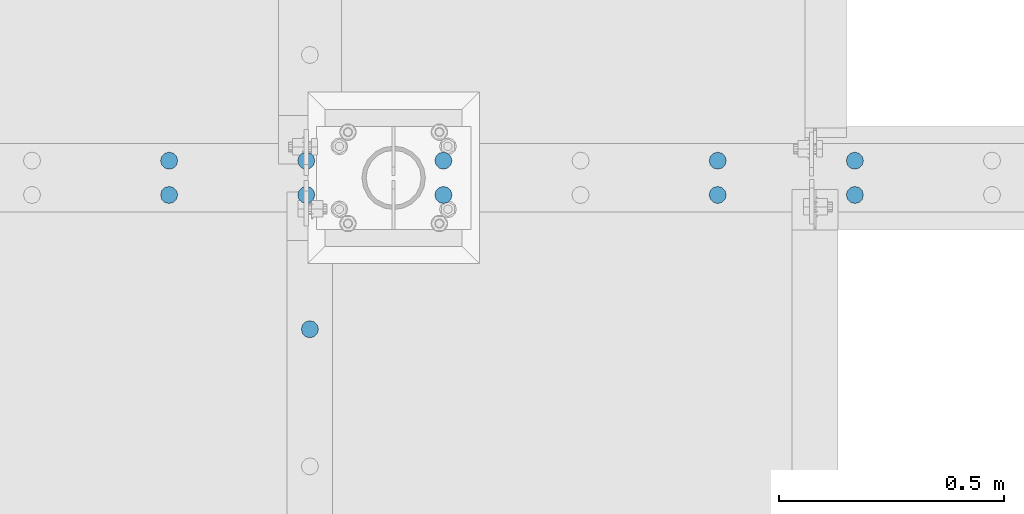
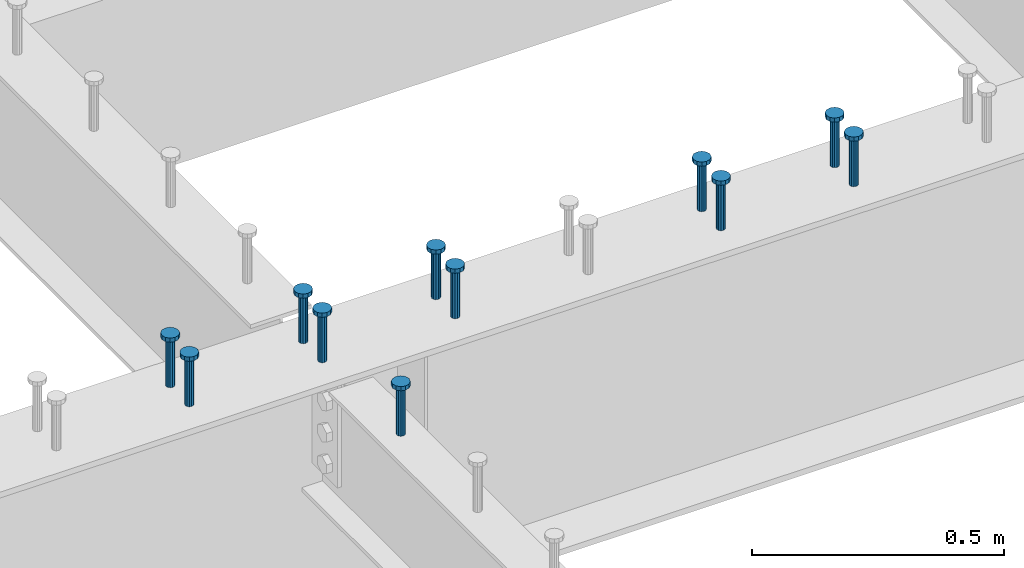
# One storey, part 148 of 975: 11 columns.
"""IFC2X3 building model written with IfcOpenShell, lengths in millimetres."""

from ifc_helpers import new_model, si_unit, frame, origin_with_axes, place, context, subcontext, project, spatial, faceted_brep, material, type_object, element, save


model = new_model("IFC2X3")

# Units and contexts
model_context = context("Model", 3, precision=1e-05, world=origin_with_axes())
body_context = subcontext(model_context, "Body", "Model", "MODEL_VIEW")
ifc_project = project(units=[si_unit("LENGTHUNIT", "METRE", prefix="MILLI"), si_unit("AREAUNIT", "SQUARE_METRE"), si_unit("VOLUMEUNIT", "CUBIC_METRE"), si_unit("MASSUNIT", "GRAM", prefix="KILO"), si_unit("TIMEUNIT", "SECOND"), si_unit("PLANEANGLEUNIT", "RADIAN"), si_unit("SOLIDANGLEUNIT", "STERADIAN"), si_unit("THERMODYNAMICTEMPERATUREUNIT", "DEGREE_CELSIUS"), si_unit("LUMINOUSINTENSITYUNIT", "LUMEN")], contexts=[model_context])

# Site, building, storey
site_placement = place(None, origin_with_axes())
site = spatial("IfcSite", under=ifc_project, at=site_placement, CompositionType="ELEMENT")
building_placement = place(site_placement, origin_with_axes())
building = spatial("IfcBuilding", under=site, at=building_placement, Name="Undefined", CompositionType="ELEMENT")
storey_placement = place(building_placement, origin_with_axes())
storey = spatial("IfcBuildingStorey", under=building, at=storey_placement, Name="Undefined", CompositionType="ELEMENT", Elevation=0.0)

# Columns
ifc_material = material(Name="STEEL/A108")
column_type = type_object("IfcColumnType", Name="STUD_3/4-DIA", PredefinedType="NOTDEFINED")
column_1_placement = place(storey_placement, frame((4290.48345841015, 5483.225, 3937.0), z_axis=(0.0, 1.0, 0.0), x_axis=(0.0, 0.0, 1.0)))
element("IfcColumn", 1, at=column_1_placement, inside=storey, type_object=column_type, material=ifc_material, ObjectType="STUD_3/4-DIA", context=body_context, shape_type="Brep", body=[
    faceted_brep([(0.0, -9.52000045776367, 0.0), (0.0, -8.25, -4.76000022888184), (115.57, -8.25, -4.76000022888184), (115.57, -9.52000045776367, 0.0), (0.0, -4.76000022888184, -8.25), (115.57, -4.76000022888184, -8.25), (0.0, 0.0, -9.52000045776367), (115.57, 0.0, -9.52000045776367), (0.0, 4.76000022888184, -8.25), (115.57, 4.76000022888184, -8.25), (0.0, 8.25, -4.76000022888184), (115.57, 8.25, -4.76000022888184), (0.0, 9.52000045776367, 0.0), (115.57, 9.52000045776367, 0.0), (0.0, 8.25, 4.76000022888184), (115.57, 8.25, 4.76000022888184), (0.0, 4.76000022888184, 8.25), (115.57, 4.76000022888184, 8.25), (0.0, 0.0, 9.52000045776367), (115.57, 0.0, 9.52000045776367), (0.0, -4.76000022888184, 8.25), (115.57, -4.76000022888184, 8.25), (0.0, -8.25, 4.76000022888184), (115.57, -8.25, 4.76000022888184), (116.84, -16.5, -9.52000045776367), (116.84, -19.0499992370605, 0.0), (116.84, -9.52000045776367, -16.5), (116.84, 0.0, -19.0499992370605), (116.84, 9.52000045776367, -16.5), (116.84, 16.5, -9.52000045776367), (116.84, 19.0499992370605, 0.0), (116.84, 16.5, 9.52000045776367), (116.84, 9.52000045776367, 16.5), (116.84, 0.0, 19.0499992370605), (116.84, -9.52000045776367, 16.5), (116.84, -16.5, 9.52000045776367), (127.0, -16.5, -9.52000045776367), (127.0, -19.0499992370605, 0.0), (127.0, -9.52000045776367, -16.5), (127.0, 0.0, -19.0499992370605), (127.0, 9.52000045776367, -16.5), (127.0, 16.5, -9.52000045776367), (127.0, 19.0499992370605, 0.0), (127.0, 16.5, 9.52000045776367), (127.0, 9.52000045776367, 16.5), (127.0, 0.0, 19.0499992370605), (127.0, -9.52000045776367, 16.5), (127.0, -16.5, 9.52000045776367)], [[[0, 1, 2, 3]], [[1, 4, 5, 2]], [[4, 6, 7, 5]], [[6, 8, 9, 7]], [[8, 10, 11, 9]], [[10, 12, 13, 11]], [[12, 14, 15, 13]], [[14, 16, 17, 15]], [[16, 18, 19, 17]], [[18, 20, 21, 19]], [[20, 22, 23, 21]], [[22, 0, 3, 23]], [[22, 20, 18, 16, 14, 12, 10, 8, 6, 4, 1, 0]], [[3, 2, 24, 25]], [[2, 5, 26, 24]], [[5, 7, 27, 26]], [[7, 9, 28, 27]], [[9, 11, 29, 28]], [[11, 13, 30, 29]], [[13, 15, 31, 30]], [[15, 17, 32, 31]], [[17, 19, 33, 32]], [[19, 21, 34, 33]], [[21, 23, 35, 34]], [[23, 3, 25, 35]], [[25, 24, 36, 37]], [[24, 26, 38, 36]], [[26, 27, 39, 38]], [[27, 28, 40, 39]], [[28, 29, 41, 40]], [[29, 30, 42, 41]], [[30, 31, 43, 42]], [[31, 32, 44, 43]], [[32, 33, 45, 44]], [[33, 34, 46, 45]], [[34, 35, 47, 46]], [[35, 25, 37, 47]], [[38, 39, 40, 41, 42, 43, 44, 45, 46, 47, 37, 36]]]),
])
column_2_placement = place(storey_placement, frame((5501.74595841015, 5781.675, 3937.0), z_axis=(0.0, 1.0, 0.0), x_axis=(0.0, 0.0, 1.0)))
element("IfcColumn", 2, at=column_2_placement, inside=storey, type_object=column_type, material=ifc_material, ObjectType="STUD_3/4-DIA", context=body_context, shape_type="Brep", body=[
    faceted_brep([(0.0, -9.52000045776367, 0.0), (0.0, -8.25, -4.76000022888184), (115.57, -8.25, -4.76000022888184), (115.57, -9.52000045776367, 0.0), (0.0, -4.76000022888184, -8.25), (115.57, -4.76000022888184, -8.25), (0.0, 0.0, -9.52000045776367), (115.57, 0.0, -9.52000045776367), (0.0, 4.76000022888184, -8.25), (115.57, 4.76000022888184, -8.25), (0.0, 8.25, -4.76000022888184), (115.57, 8.25, -4.76000022888184), (0.0, 9.52000045776367, 0.0), (115.57, 9.52000045776367, 0.0), (0.0, 8.25, 4.76000022888184), (115.57, 8.25, 4.76000022888184), (0.0, 4.76000022888184, 8.25), (115.57, 4.76000022888184, 8.25), (0.0, 0.0, 9.52000045776367), (115.57, 0.0, 9.52000045776367), (0.0, -4.76000022888184, 8.25), (115.57, -4.76000022888184, 8.25), (0.0, -8.25, 4.76000022888184), (115.57, -8.25, 4.76000022888184), (116.84, -16.5, -9.52000045776367), (116.84, -19.0499992370605, 0.0), (116.84, -9.52000045776367, -16.5), (116.84, 0.0, -19.0499992370605), (116.84, 9.52000045776367, -16.5), (116.84, 16.5, -9.52000045776367), (116.84, 19.0499992370605, 0.0), (116.84, 16.5, 9.52000045776367), (116.84, 9.52000045776367, 16.5), (116.84, 0.0, 19.0499992370605), (116.84, -9.52000045776367, 16.5), (116.84, -16.5, 9.52000045776367), (127.0, -16.5, -9.52000045776367), (127.0, -19.0499992370605, 0.0), (127.0, -9.52000045776367, -16.5), (127.0, 0.0, -19.0499992370605), (127.0, 9.52000045776367, -16.5), (127.0, 16.5, -9.52000045776367), (127.0, 19.0499992370605, 0.0), (127.0, 16.5, 9.52000045776367), (127.0, 9.52000045776367, 16.5), (127.0, 0.0, 19.0499992370605), (127.0, -9.52000045776367, 16.5), (127.0, -16.5, 9.52000045776367)], [[[0, 1, 2, 3]], [[1, 4, 5, 2]], [[4, 6, 7, 5]], [[6, 8, 9, 7]], [[8, 10, 11, 9]], [[10, 12, 13, 11]], [[12, 14, 15, 13]], [[14, 16, 17, 15]], [[16, 18, 19, 17]], [[18, 20, 21, 19]], [[20, 22, 23, 21]], [[22, 0, 3, 23]], [[22, 20, 18, 16, 14, 12, 10, 8, 6, 4, 1, 0]], [[3, 2, 24, 25]], [[2, 5, 26, 24]], [[5, 7, 27, 26]], [[7, 9, 28, 27]], [[9, 11, 29, 28]], [[11, 13, 30, 29]], [[13, 15, 31, 30]], [[15, 17, 32, 31]], [[17, 19, 33, 32]], [[19, 21, 34, 33]], [[21, 23, 35, 34]], [[23, 3, 25, 35]], [[25, 24, 36, 37]], [[24, 26, 38, 36]], [[26, 27, 39, 38]], [[27, 28, 40, 39]], [[28, 29, 41, 40]], [[29, 30, 42, 41]], [[30, 31, 43, 42]], [[31, 32, 44, 43]], [[32, 33, 45, 44]], [[33, 34, 46, 45]], [[34, 35, 47, 46]], [[35, 25, 37, 47]], [[38, 39, 40, 41, 42, 43, 44, 45, 46, 47, 37, 36]]]),
])
column_3_placement = place(storey_placement, frame((5501.74595841015, 5857.875, 3937.0), z_axis=(0.0, 1.0, 0.0), x_axis=(0.0, 0.0, 1.0)))
element("IfcColumn", 3, at=column_3_placement, inside=storey, type_object=column_type, material=ifc_material, ObjectType="STUD_3/4-DIA", context=body_context, shape_type="Brep", body=[
    faceted_brep([(0.0, -9.52000045776367, 0.0), (0.0, -8.25, -4.76000022888184), (115.57, -8.25, -4.76000022888184), (115.57, -9.52000045776367, 0.0), (0.0, -4.76000022888184, -8.25), (115.57, -4.76000022888184, -8.25), (0.0, 0.0, -9.52000045776367), (115.57, 0.0, -9.52000045776367), (0.0, 4.76000022888184, -8.25), (115.57, 4.76000022888184, -8.25), (0.0, 8.25, -4.76000022888184), (115.57, 8.25, -4.76000022888184), (0.0, 9.52000045776367, 0.0), (115.57, 9.52000045776367, 0.0), (0.0, 8.25, 4.76000022888184), (115.57, 8.25, 4.76000022888184), (0.0, 4.76000022888184, 8.25), (115.57, 4.76000022888184, 8.25), (0.0, 0.0, 9.52000045776367), (115.57, 0.0, 9.52000045776367), (0.0, -4.76000022888184, 8.25), (115.57, -4.76000022888184, 8.25), (0.0, -8.25, 4.76000022888184), (115.57, -8.25, 4.76000022888184), (116.84, -16.5, -9.52000045776367), (116.84, -19.0499992370605, 0.0), (116.84, -9.52000045776367, -16.5), (116.84, 0.0, -19.0499992370605), (116.84, 9.52000045776367, -16.5), (116.84, 16.5, -9.52000045776367), (116.84, 19.0499992370605, 0.0), (116.84, 16.5, 9.52000045776367), (116.84, 9.52000045776367, 16.5), (116.84, 0.0, 19.0499992370605), (116.84, -9.52000045776367, 16.5), (116.84, -16.5, 9.52000045776367), (127.0, -16.5, -9.52000045776367), (127.0, -19.0499992370605, 0.0), (127.0, -9.52000045776367, -16.5), (127.0, 0.0, -19.0499992370605), (127.0, 9.52000045776367, -16.5), (127.0, 16.5, -9.52000045776367), (127.0, 19.0499992370605, 0.0), (127.0, 16.5, 9.52000045776367), (127.0, 9.52000045776367, 16.5), (127.0, 0.0, 19.0499992370605), (127.0, -9.52000045776367, 16.5), (127.0, -16.5, 9.52000045776367)], [[[0, 1, 2, 3]], [[1, 4, 5, 2]], [[4, 6, 7, 5]], [[6, 8, 9, 7]], [[8, 10, 11, 9]], [[10, 12, 13, 11]], [[12, 14, 15, 13]], [[14, 16, 17, 15]], [[16, 18, 19, 17]], [[18, 20, 21, 19]], [[20, 22, 23, 21]], [[22, 0, 3, 23]], [[22, 20, 18, 16, 14, 12, 10, 8, 6, 4, 1, 0]], [[3, 2, 24, 25]], [[2, 5, 26, 24]], [[5, 7, 27, 26]], [[7, 9, 28, 27]], [[9, 11, 29, 28]], [[11, 13, 30, 29]], [[13, 15, 31, 30]], [[15, 17, 32, 31]], [[17, 19, 33, 32]], [[19, 21, 34, 33]], [[21, 23, 35, 34]], [[23, 3, 25, 35]], [[25, 24, 36, 37]], [[24, 26, 38, 36]], [[26, 27, 39, 38]], [[27, 28, 40, 39]], [[28, 29, 41, 40]], [[29, 30, 42, 41]], [[30, 31, 43, 42]], [[31, 32, 44, 43]], [[32, 33, 45, 44]], [[33, 34, 46, 45]], [[34, 35, 47, 46]], [[35, 25, 37, 47]], [[38, 39, 40, 41, 42, 43, 44, 45, 46, 47, 37, 36]]]),
])
column_4_placement = place(storey_placement, frame((5196.94595841015, 5781.675, 3937.0), z_axis=(0.0, 1.0, 0.0), x_axis=(0.0, 0.0, 1.0)))
element("IfcColumn", 4, at=column_4_placement, inside=storey, type_object=column_type, material=ifc_material, ObjectType="STUD_3/4-DIA", context=body_context, shape_type="Brep", body=[
    faceted_brep([(0.0, -9.52000045776367, 0.0), (0.0, -8.25, -4.76000022888184), (115.57, -8.25, -4.76000022888184), (115.57, -9.52000045776367, 0.0), (0.0, -4.76000022888184, -8.25), (115.57, -4.76000022888184, -8.25), (0.0, 0.0, -9.52000045776367), (115.57, 0.0, -9.52000045776367), (0.0, 4.76000022888184, -8.25), (115.57, 4.76000022888184, -8.25), (0.0, 8.25, -4.76000022888184), (115.57, 8.25, -4.76000022888184), (0.0, 9.52000045776367, 0.0), (115.57, 9.52000045776367, 0.0), (0.0, 8.25, 4.76000022888184), (115.57, 8.25, 4.76000022888184), (0.0, 4.76000022888184, 8.25), (115.57, 4.76000022888184, 8.25), (0.0, 0.0, 9.52000045776367), (115.57, 0.0, 9.52000045776367), (0.0, -4.76000022888184, 8.25), (115.57, -4.76000022888184, 8.25), (0.0, -8.25, 4.76000022888184), (115.57, -8.25, 4.76000022888184), (116.84, -16.5, -9.52000045776367), (116.84, -19.0499992370605, 0.0), (116.84, -9.52000045776367, -16.5), (116.84, 0.0, -19.0499992370605), (116.84, 9.52000045776367, -16.5), (116.84, 16.5, -9.52000045776367), (116.84, 19.0499992370605, 0.0), (116.84, 16.5, 9.52000045776367), (116.84, 9.52000045776367, 16.5), (116.84, 0.0, 19.0499992370605), (116.84, -9.52000045776367, 16.5), (116.84, -16.5, 9.52000045776367), (127.0, -16.5, -9.52000045776367), (127.0, -19.0499992370605, 0.0), (127.0, -9.52000045776367, -16.5), (127.0, 0.0, -19.0499992370605), (127.0, 9.52000045776367, -16.5), (127.0, 16.5, -9.52000045776367), (127.0, 19.0499992370605, 0.0), (127.0, 16.5, 9.52000045776367), (127.0, 9.52000045776367, 16.5), (127.0, 0.0, 19.0499992370605), (127.0, -9.52000045776367, 16.5), (127.0, -16.5, 9.52000045776367)], [[[0, 1, 2, 3]], [[1, 4, 5, 2]], [[4, 6, 7, 5]], [[6, 8, 9, 7]], [[8, 10, 11, 9]], [[10, 12, 13, 11]], [[12, 14, 15, 13]], [[14, 16, 17, 15]], [[16, 18, 19, 17]], [[18, 20, 21, 19]], [[20, 22, 23, 21]], [[22, 0, 3, 23]], [[22, 20, 18, 16, 14, 12, 10, 8, 6, 4, 1, 0]], [[3, 2, 24, 25]], [[2, 5, 26, 24]], [[5, 7, 27, 26]], [[7, 9, 28, 27]], [[9, 11, 29, 28]], [[11, 13, 30, 29]], [[13, 15, 31, 30]], [[15, 17, 32, 31]], [[17, 19, 33, 32]], [[19, 21, 34, 33]], [[21, 23, 35, 34]], [[23, 3, 25, 35]], [[25, 24, 36, 37]], [[24, 26, 38, 36]], [[26, 27, 39, 38]], [[27, 28, 40, 39]], [[28, 29, 41, 40]], [[29, 30, 42, 41]], [[30, 31, 43, 42]], [[31, 32, 44, 43]], [[32, 33, 45, 44]], [[33, 34, 46, 45]], [[34, 35, 47, 46]], [[35, 25, 37, 47]], [[38, 39, 40, 41, 42, 43, 44, 45, 46, 47, 37, 36]]]),
])
column_5_placement = place(storey_placement, frame((5196.94595841015, 5857.875, 3937.0), z_axis=(0.0, 1.0, 0.0), x_axis=(0.0, 0.0, 1.0)))
element("IfcColumn", 5, at=column_5_placement, inside=storey, type_object=column_type, material=ifc_material, ObjectType="STUD_3/4-DIA", context=body_context, shape_type="Brep", body=[
    faceted_brep([(0.0, -9.52000045776367, 0.0), (0.0, -8.25, -4.76000022888184), (115.57, -8.25, -4.76000022888184), (115.57, -9.52000045776367, 0.0), (0.0, -4.76000022888184, -8.25), (115.57, -4.76000022888184, -8.25), (0.0, 0.0, -9.52000045776367), (115.57, 0.0, -9.52000045776367), (0.0, 4.76000022888184, -8.25), (115.57, 4.76000022888184, -8.25), (0.0, 8.25, -4.76000022888184), (115.57, 8.25, -4.76000022888184), (0.0, 9.52000045776367, 0.0), (115.57, 9.52000045776367, 0.0), (0.0, 8.25, 4.76000022888184), (115.57, 8.25, 4.76000022888184), (0.0, 4.76000022888184, 8.25), (115.57, 4.76000022888184, 8.25), (0.0, 0.0, 9.52000045776367), (115.57, 0.0, 9.52000045776367), (0.0, -4.76000022888184, 8.25), (115.57, -4.76000022888184, 8.25), (0.0, -8.25, 4.76000022888184), (115.57, -8.25, 4.76000022888184), (116.84, -16.5, -9.52000045776367), (116.84, -19.0499992370605, 0.0), (116.84, -9.52000045776367, -16.5), (116.84, 0.0, -19.0499992370605), (116.84, 9.52000045776367, -16.5), (116.84, 16.5, -9.52000045776367), (116.84, 19.0499992370605, 0.0), (116.84, 16.5, 9.52000045776367), (116.84, 9.52000045776367, 16.5), (116.84, 0.0, 19.0499992370605), (116.84, -9.52000045776367, 16.5), (116.84, -16.5, 9.52000045776367), (127.0, -16.5, -9.52000045776367), (127.0, -19.0499992370605, 0.0), (127.0, -9.52000045776367, -16.5), (127.0, 0.0, -19.0499992370605), (127.0, 9.52000045776367, -16.5), (127.0, 16.5, -9.52000045776367), (127.0, 19.0499992370605, 0.0), (127.0, 16.5, 9.52000045776367), (127.0, 9.52000045776367, 16.5), (127.0, 0.0, 19.0499992370605), (127.0, -9.52000045776367, 16.5), (127.0, -16.5, 9.52000045776367)], [[[0, 1, 2, 3]], [[1, 4, 5, 2]], [[4, 6, 7, 5]], [[6, 8, 9, 7]], [[8, 10, 11, 9]], [[10, 12, 13, 11]], [[12, 14, 15, 13]], [[14, 16, 17, 15]], [[16, 18, 19, 17]], [[18, 20, 21, 19]], [[20, 22, 23, 21]], [[22, 0, 3, 23]], [[22, 20, 18, 16, 14, 12, 10, 8, 6, 4, 1, 0]], [[3, 2, 24, 25]], [[2, 5, 26, 24]], [[5, 7, 27, 26]], [[7, 9, 28, 27]], [[9, 11, 29, 28]], [[11, 13, 30, 29]], [[13, 15, 31, 30]], [[15, 17, 32, 31]], [[17, 19, 33, 32]], [[19, 21, 34, 33]], [[21, 23, 35, 34]], [[23, 3, 25, 35]], [[25, 24, 36, 37]], [[24, 26, 38, 36]], [[26, 27, 39, 38]], [[27, 28, 40, 39]], [[28, 29, 41, 40]], [[29, 30, 42, 41]], [[30, 31, 43, 42]], [[31, 32, 44, 43]], [[32, 33, 45, 44]], [[33, 34, 46, 45]], [[34, 35, 47, 46]], [[35, 25, 37, 47]], [[38, 39, 40, 41, 42, 43, 44, 45, 46, 47, 37, 36]]]),
])
column_6_placement = place(storey_placement, frame((4587.34595841015, 5781.675, 3937.0), z_axis=(0.0, 1.0, 0.0), x_axis=(0.0, 0.0, 1.0)))
element("IfcColumn", 6, at=column_6_placement, inside=storey, type_object=column_type, material=ifc_material, ObjectType="STUD_3/4-DIA", context=body_context, shape_type="Brep", body=[
    faceted_brep([(0.0, -9.52000045776367, 0.0), (0.0, -8.25, -4.76000022888184), (115.57, -8.25, -4.76000022888184), (115.57, -9.52000045776367, 0.0), (0.0, -4.76000022888184, -8.25), (115.57, -4.76000022888184, -8.25), (0.0, 0.0, -9.52000045776367), (115.57, 0.0, -9.52000045776367), (0.0, 4.76000022888184, -8.25), (115.57, 4.76000022888184, -8.25), (0.0, 8.25, -4.76000022888184), (115.57, 8.25, -4.76000022888184), (0.0, 9.52000045776367, 0.0), (115.57, 9.52000045776367, 0.0), (0.0, 8.25, 4.76000022888184), (115.57, 8.25, 4.76000022888184), (0.0, 4.76000022888184, 8.25), (115.57, 4.76000022888184, 8.25), (0.0, 0.0, 9.52000045776367), (115.57, 0.0, 9.52000045776367), (0.0, -4.76000022888184, 8.25), (115.57, -4.76000022888184, 8.25), (0.0, -8.25, 4.76000022888184), (115.57, -8.25, 4.76000022888184), (116.84, -16.5, -9.52000045776367), (116.84, -19.0499992370605, 0.0), (116.84, -9.52000045776367, -16.5), (116.84, 0.0, -19.0499992370605), (116.84, 9.52000045776367, -16.5), (116.84, 16.5, -9.52000045776367), (116.84, 19.0499992370605, 0.0), (116.84, 16.5, 9.52000045776367), (116.84, 9.52000045776367, 16.5), (116.84, 0.0, 19.0499992370605), (116.84, -9.52000045776367, 16.5), (116.84, -16.5, 9.52000045776367), (127.0, -16.5, -9.52000045776367), (127.0, -19.0499992370605, 0.0), (127.0, -9.52000045776367, -16.5), (127.0, 0.0, -19.0499992370605), (127.0, 9.52000045776367, -16.5), (127.0, 16.5, -9.52000045776367), (127.0, 19.0499992370605, 0.0), (127.0, 16.5, 9.52000045776367), (127.0, 9.52000045776367, 16.5), (127.0, 0.0, 19.0499992370605), (127.0, -9.52000045776367, 16.5), (127.0, -16.5, 9.52000045776367)], [[[0, 1, 2, 3]], [[1, 4, 5, 2]], [[4, 6, 7, 5]], [[6, 8, 9, 7]], [[8, 10, 11, 9]], [[10, 12, 13, 11]], [[12, 14, 15, 13]], [[14, 16, 17, 15]], [[16, 18, 19, 17]], [[18, 20, 21, 19]], [[20, 22, 23, 21]], [[22, 0, 3, 23]], [[22, 20, 18, 16, 14, 12, 10, 8, 6, 4, 1, 0]], [[3, 2, 24, 25]], [[2, 5, 26, 24]], [[5, 7, 27, 26]], [[7, 9, 28, 27]], [[9, 11, 29, 28]], [[11, 13, 30, 29]], [[13, 15, 31, 30]], [[15, 17, 32, 31]], [[17, 19, 33, 32]], [[19, 21, 34, 33]], [[21, 23, 35, 34]], [[23, 3, 25, 35]], [[25, 24, 36, 37]], [[24, 26, 38, 36]], [[26, 27, 39, 38]], [[27, 28, 40, 39]], [[28, 29, 41, 40]], [[29, 30, 42, 41]], [[30, 31, 43, 42]], [[31, 32, 44, 43]], [[32, 33, 45, 44]], [[33, 34, 46, 45]], [[34, 35, 47, 46]], [[35, 25, 37, 47]], [[38, 39, 40, 41, 42, 43, 44, 45, 46, 47, 37, 36]]]),
])
column_7_placement = place(storey_placement, frame((4587.34595841015, 5857.875, 3937.0), z_axis=(0.0, 1.0, 0.0), x_axis=(0.0, 0.0, 1.0)))
element("IfcColumn", 7, at=column_7_placement, inside=storey, type_object=column_type, material=ifc_material, ObjectType="STUD_3/4-DIA", context=body_context, shape_type="Brep", body=[
    faceted_brep([(0.0, -9.52000045776367, 0.0), (0.0, -8.25, -4.76000022888184), (115.57, -8.25, -4.76000022888184), (115.57, -9.52000045776367, 0.0), (0.0, -4.76000022888184, -8.25), (115.57, -4.76000022888184, -8.25), (0.0, 0.0, -9.52000045776367), (115.57, 0.0, -9.52000045776367), (0.0, 4.76000022888184, -8.25), (115.57, 4.76000022888184, -8.25), (0.0, 8.25, -4.76000022888184), (115.57, 8.25, -4.76000022888184), (0.0, 9.52000045776367, 0.0), (115.57, 9.52000045776367, 0.0), (0.0, 8.25, 4.76000022888184), (115.57, 8.25, 4.76000022888184), (0.0, 4.76000022888184, 8.25), (115.57, 4.76000022888184, 8.25), (0.0, 0.0, 9.52000045776367), (115.57, 0.0, 9.52000045776367), (0.0, -4.76000022888184, 8.25), (115.57, -4.76000022888184, 8.25), (0.0, -8.25, 4.76000022888184), (115.57, -8.25, 4.76000022888184), (116.84, -16.5, -9.52000045776367), (116.84, -19.0499992370605, 0.0), (116.84, -9.52000045776367, -16.5), (116.84, 0.0, -19.0499992370605), (116.84, 9.52000045776367, -16.5), (116.84, 16.5, -9.52000045776367), (116.84, 19.0499992370605, 0.0), (116.84, 16.5, 9.52000045776367), (116.84, 9.52000045776367, 16.5), (116.84, 0.0, 19.0499992370605), (116.84, -9.52000045776367, 16.5), (116.84, -16.5, 9.52000045776367), (127.0, -16.5, -9.52000045776367), (127.0, -19.0499992370605, 0.0), (127.0, -9.52000045776367, -16.5), (127.0, 0.0, -19.0499992370605), (127.0, 9.52000045776367, -16.5), (127.0, 16.5, -9.52000045776367), (127.0, 19.0499992370605, 0.0), (127.0, 16.5, 9.52000045776367), (127.0, 9.52000045776367, 16.5), (127.0, 0.0, 19.0499992370605), (127.0, -9.52000045776367, 16.5), (127.0, -16.5, 9.52000045776367)], [[[0, 1, 2, 3]], [[1, 4, 5, 2]], [[4, 6, 7, 5]], [[6, 8, 9, 7]], [[8, 10, 11, 9]], [[10, 12, 13, 11]], [[12, 14, 15, 13]], [[14, 16, 17, 15]], [[16, 18, 19, 17]], [[18, 20, 21, 19]], [[20, 22, 23, 21]], [[22, 0, 3, 23]], [[22, 20, 18, 16, 14, 12, 10, 8, 6, 4, 1, 0]], [[3, 2, 24, 25]], [[2, 5, 26, 24]], [[5, 7, 27, 26]], [[7, 9, 28, 27]], [[9, 11, 29, 28]], [[11, 13, 30, 29]], [[13, 15, 31, 30]], [[15, 17, 32, 31]], [[17, 19, 33, 32]], [[19, 21, 34, 33]], [[21, 23, 35, 34]], [[23, 3, 25, 35]], [[25, 24, 36, 37]], [[24, 26, 38, 36]], [[26, 27, 39, 38]], [[27, 28, 40, 39]], [[28, 29, 41, 40]], [[29, 30, 42, 41]], [[30, 31, 43, 42]], [[31, 32, 44, 43]], [[32, 33, 45, 44]], [[33, 34, 46, 45]], [[34, 35, 47, 46]], [[35, 25, 37, 47]], [[38, 39, 40, 41, 42, 43, 44, 45, 46, 47, 37, 36]]]),
])
column_8_placement = place(storey_placement, frame((4282.54595841015, 5781.675, 3937.0), z_axis=(0.0, 1.0, 0.0), x_axis=(0.0, 0.0, 1.0)))
element("IfcColumn", 8, at=column_8_placement, inside=storey, type_object=column_type, material=ifc_material, ObjectType="STUD_3/4-DIA", context=body_context, shape_type="Brep", body=[
    faceted_brep([(0.0, -9.52000045776367, 0.0), (0.0, -8.25, -4.76000022888184), (115.57, -8.25, -4.76000022888184), (115.57, -9.52000045776367, 0.0), (0.0, -4.76000022888184, -8.25), (115.57, -4.76000022888184, -8.25), (0.0, 0.0, -9.52000045776367), (115.57, 0.0, -9.52000045776367), (0.0, 4.76000022888184, -8.25), (115.57, 4.76000022888184, -8.25), (0.0, 8.25, -4.76000022888184), (115.57, 8.25, -4.76000022888184), (0.0, 9.52000045776367, 0.0), (115.57, 9.52000045776367, 0.0), (0.0, 8.25, 4.76000022888184), (115.57, 8.25, 4.76000022888184), (0.0, 4.76000022888184, 8.25), (115.57, 4.76000022888184, 8.25), (0.0, 0.0, 9.52000045776367), (115.57, 0.0, 9.52000045776367), (0.0, -4.76000022888184, 8.25), (115.57, -4.76000022888184, 8.25), (0.0, -8.25, 4.76000022888184), (115.57, -8.25, 4.76000022888184), (116.84, -16.5, -9.52000045776367), (116.84, -19.0499992370605, 0.0), (116.84, -9.52000045776367, -16.5), (116.84, 0.0, -19.0499992370605), (116.84, 9.52000045776367, -16.5), (116.84, 16.5, -9.52000045776367), (116.84, 19.0499992370605, 0.0), (116.84, 16.5, 9.52000045776367), (116.84, 9.52000045776367, 16.5), (116.84, 0.0, 19.0499992370605), (116.84, -9.52000045776367, 16.5), (116.84, -16.5, 9.52000045776367), (127.0, -16.5, -9.52000045776367), (127.0, -19.0499992370605, 0.0), (127.0, -9.52000045776367, -16.5), (127.0, 0.0, -19.0499992370605), (127.0, 9.52000045776367, -16.5), (127.0, 16.5, -9.52000045776367), (127.0, 19.0499992370605, 0.0), (127.0, 16.5, 9.52000045776367), (127.0, 9.52000045776367, 16.5), (127.0, 0.0, 19.0499992370605), (127.0, -9.52000045776367, 16.5), (127.0, -16.5, 9.52000045776367)], [[[0, 1, 2, 3]], [[1, 4, 5, 2]], [[4, 6, 7, 5]], [[6, 8, 9, 7]], [[8, 10, 11, 9]], [[10, 12, 13, 11]], [[12, 14, 15, 13]], [[14, 16, 17, 15]], [[16, 18, 19, 17]], [[18, 20, 21, 19]], [[20, 22, 23, 21]], [[22, 0, 3, 23]], [[22, 20, 18, 16, 14, 12, 10, 8, 6, 4, 1, 0]], [[3, 2, 24, 25]], [[2, 5, 26, 24]], [[5, 7, 27, 26]], [[7, 9, 28, 27]], [[9, 11, 29, 28]], [[11, 13, 30, 29]], [[13, 15, 31, 30]], [[15, 17, 32, 31]], [[17, 19, 33, 32]], [[19, 21, 34, 33]], [[21, 23, 35, 34]], [[23, 3, 25, 35]], [[25, 24, 36, 37]], [[24, 26, 38, 36]], [[26, 27, 39, 38]], [[27, 28, 40, 39]], [[28, 29, 41, 40]], [[29, 30, 42, 41]], [[30, 31, 43, 42]], [[31, 32, 44, 43]], [[32, 33, 45, 44]], [[33, 34, 46, 45]], [[34, 35, 47, 46]], [[35, 25, 37, 47]], [[38, 39, 40, 41, 42, 43, 44, 45, 46, 47, 37, 36]]]),
])
column_9_placement = place(storey_placement, frame((4282.54595841015, 5857.875, 3937.0), z_axis=(0.0, 1.0, 0.0), x_axis=(0.0, 0.0, 1.0)))
element("IfcColumn", 9, at=column_9_placement, inside=storey, type_object=column_type, material=ifc_material, ObjectType="STUD_3/4-DIA", context=body_context, shape_type="Brep", body=[
    faceted_brep([(0.0, -9.52000045776367, 0.0), (0.0, -8.25, -4.76000022888184), (115.57, -8.25, -4.76000022888184), (115.57, -9.52000045776367, 0.0), (0.0, -4.76000022888184, -8.25), (115.57, -4.76000022888184, -8.25), (0.0, 0.0, -9.52000045776367), (115.57, 0.0, -9.52000045776367), (0.0, 4.76000022888184, -8.25), (115.57, 4.76000022888184, -8.25), (0.0, 8.25, -4.76000022888184), (115.57, 8.25, -4.76000022888184), (0.0, 9.52000045776367, 0.0), (115.57, 9.52000045776367, 0.0), (0.0, 8.25, 4.76000022888184), (115.57, 8.25, 4.76000022888184), (0.0, 4.76000022888184, 8.25), (115.57, 4.76000022888184, 8.25), (0.0, 0.0, 9.52000045776367), (115.57, 0.0, 9.52000045776367), (0.0, -4.76000022888184, 8.25), (115.57, -4.76000022888184, 8.25), (0.0, -8.25, 4.76000022888184), (115.57, -8.25, 4.76000022888184), (116.84, -16.5, -9.52000045776367), (116.84, -19.0499992370605, 0.0), (116.84, -9.52000045776367, -16.5), (116.84, 0.0, -19.0499992370605), (116.84, 9.52000045776367, -16.5), (116.84, 16.5, -9.52000045776367), (116.84, 19.0499992370605, 0.0), (116.84, 16.5, 9.52000045776367), (116.84, 9.52000045776367, 16.5), (116.84, 0.0, 19.0499992370605), (116.84, -9.52000045776367, 16.5), (116.84, -16.5, 9.52000045776367), (127.0, -16.5, -9.52000045776367), (127.0, -19.0499992370605, 0.0), (127.0, -9.52000045776367, -16.5), (127.0, 0.0, -19.0499992370605), (127.0, 9.52000045776367, -16.5), (127.0, 16.5, -9.52000045776367), (127.0, 19.0499992370605, 0.0), (127.0, 16.5, 9.52000045776367), (127.0, 9.52000045776367, 16.5), (127.0, 0.0, 19.0499992370605), (127.0, -9.52000045776367, 16.5), (127.0, -16.5, 9.52000045776367)], [[[0, 1, 2, 3]], [[1, 4, 5, 2]], [[4, 6, 7, 5]], [[6, 8, 9, 7]], [[8, 10, 11, 9]], [[10, 12, 13, 11]], [[12, 14, 15, 13]], [[14, 16, 17, 15]], [[16, 18, 19, 17]], [[18, 20, 21, 19]], [[20, 22, 23, 21]], [[22, 0, 3, 23]], [[22, 20, 18, 16, 14, 12, 10, 8, 6, 4, 1, 0]], [[3, 2, 24, 25]], [[2, 5, 26, 24]], [[5, 7, 27, 26]], [[7, 9, 28, 27]], [[9, 11, 29, 28]], [[11, 13, 30, 29]], [[13, 15, 31, 30]], [[15, 17, 32, 31]], [[17, 19, 33, 32]], [[19, 21, 34, 33]], [[21, 23, 35, 34]], [[23, 3, 25, 35]], [[25, 24, 36, 37]], [[24, 26, 38, 36]], [[26, 27, 39, 38]], [[27, 28, 40, 39]], [[28, 29, 41, 40]], [[29, 30, 42, 41]], [[30, 31, 43, 42]], [[31, 32, 44, 43]], [[32, 33, 45, 44]], [[33, 34, 46, 45]], [[34, 35, 47, 46]], [[35, 25, 37, 47]], [[38, 39, 40, 41, 42, 43, 44, 45, 46, 47, 37, 36]]]),
])
column_10_placement = place(storey_placement, frame((3977.74595841015, 5781.675, 3937.0), z_axis=(0.0, 1.0, 0.0), x_axis=(0.0, 0.0, 1.0)))
element("IfcColumn", 10, at=column_10_placement, inside=storey, type_object=column_type, material=ifc_material, ObjectType="STUD_3/4-DIA", context=body_context, shape_type="Brep", body=[
    faceted_brep([(0.0, -9.52000045776367, 0.0), (0.0, -8.25, -4.76000022888184), (115.57, -8.25, -4.76000022888184), (115.57, -9.52000045776367, 0.0), (0.0, -4.76000022888184, -8.25), (115.57, -4.76000022888184, -8.25), (0.0, 0.0, -9.52000045776367), (115.57, 0.0, -9.52000045776367), (0.0, 4.76000022888184, -8.25), (115.57, 4.76000022888184, -8.25), (0.0, 8.25, -4.76000022888184), (115.57, 8.25, -4.76000022888184), (0.0, 9.52000045776367, 0.0), (115.57, 9.52000045776367, 0.0), (0.0, 8.25, 4.76000022888184), (115.57, 8.25, 4.76000022888184), (0.0, 4.76000022888184, 8.25), (115.57, 4.76000022888184, 8.25), (0.0, 0.0, 9.52000045776367), (115.57, 0.0, 9.52000045776367), (0.0, -4.76000022888184, 8.25), (115.57, -4.76000022888184, 8.25), (0.0, -8.25, 4.76000022888184), (115.57, -8.25, 4.76000022888184), (116.84, -16.5, -9.52000045776367), (116.84, -19.0499992370605, 0.0), (116.84, -9.52000045776367, -16.5), (116.84, 0.0, -19.0499992370605), (116.84, 9.52000045776367, -16.5), (116.84, 16.5, -9.52000045776367), (116.84, 19.0499992370605, 0.0), (116.84, 16.5, 9.52000045776367), (116.84, 9.52000045776367, 16.5), (116.84, 0.0, 19.0499992370605), (116.84, -9.52000045776367, 16.5), (116.84, -16.5, 9.52000045776367), (127.0, -16.5, -9.52000045776367), (127.0, -19.0499992370605, 0.0), (127.0, -9.52000045776367, -16.5), (127.0, 0.0, -19.0499992370605), (127.0, 9.52000045776367, -16.5), (127.0, 16.5, -9.52000045776367), (127.0, 19.0499992370605, 0.0), (127.0, 16.5, 9.52000045776367), (127.0, 9.52000045776367, 16.5), (127.0, 0.0, 19.0499992370605), (127.0, -9.52000045776367, 16.5), (127.0, -16.5, 9.52000045776367)], [[[0, 1, 2, 3]], [[1, 4, 5, 2]], [[4, 6, 7, 5]], [[6, 8, 9, 7]], [[8, 10, 11, 9]], [[10, 12, 13, 11]], [[12, 14, 15, 13]], [[14, 16, 17, 15]], [[16, 18, 19, 17]], [[18, 20, 21, 19]], [[20, 22, 23, 21]], [[22, 0, 3, 23]], [[22, 20, 18, 16, 14, 12, 10, 8, 6, 4, 1, 0]], [[3, 2, 24, 25]], [[2, 5, 26, 24]], [[5, 7, 27, 26]], [[7, 9, 28, 27]], [[9, 11, 29, 28]], [[11, 13, 30, 29]], [[13, 15, 31, 30]], [[15, 17, 32, 31]], [[17, 19, 33, 32]], [[19, 21, 34, 33]], [[21, 23, 35, 34]], [[23, 3, 25, 35]], [[25, 24, 36, 37]], [[24, 26, 38, 36]], [[26, 27, 39, 38]], [[27, 28, 40, 39]], [[28, 29, 41, 40]], [[29, 30, 42, 41]], [[30, 31, 43, 42]], [[31, 32, 44, 43]], [[32, 33, 45, 44]], [[33, 34, 46, 45]], [[34, 35, 47, 46]], [[35, 25, 37, 47]], [[38, 39, 40, 41, 42, 43, 44, 45, 46, 47, 37, 36]]]),
])
column_11_placement = place(storey_placement, frame((3977.74595841015, 5857.875, 3937.0), z_axis=(0.0, 1.0, 0.0), x_axis=(0.0, 0.0, 1.0)))
element("IfcColumn", 11, at=column_11_placement, inside=storey, type_object=column_type, material=ifc_material, ObjectType="STUD_3/4-DIA", context=body_context, shape_type="Brep", body=[
    faceted_brep([(0.0, -9.52000045776367, 0.0), (0.0, -8.25, -4.76000022888184), (115.57, -8.25, -4.76000022888184), (115.57, -9.52000045776367, 0.0), (0.0, -4.76000022888184, -8.25), (115.57, -4.76000022888184, -8.25), (0.0, 0.0, -9.52000045776367), (115.57, 0.0, -9.52000045776367), (0.0, 4.76000022888184, -8.25), (115.57, 4.76000022888184, -8.25), (0.0, 8.25, -4.76000022888184), (115.57, 8.25, -4.76000022888184), (0.0, 9.52000045776367, 0.0), (115.57, 9.52000045776367, 0.0), (0.0, 8.25, 4.76000022888184), (115.57, 8.25, 4.76000022888184), (0.0, 4.76000022888184, 8.25), (115.57, 4.76000022888184, 8.25), (0.0, 0.0, 9.52000045776367), (115.57, 0.0, 9.52000045776367), (0.0, -4.76000022888184, 8.25), (115.57, -4.76000022888184, 8.25), (0.0, -8.25, 4.76000022888184), (115.57, -8.25, 4.76000022888184), (116.84, -16.5, -9.52000045776367), (116.84, -19.0499992370605, 0.0), (116.84, -9.52000045776367, -16.5), (116.84, 0.0, -19.0499992370605), (116.84, 9.52000045776367, -16.5), (116.84, 16.5, -9.52000045776367), (116.84, 19.0499992370605, 0.0), (116.84, 16.5, 9.52000045776367), (116.84, 9.52000045776367, 16.5), (116.84, 0.0, 19.0499992370605), (116.84, -9.52000045776367, 16.5), (116.84, -16.5, 9.52000045776367), (127.0, -16.5, -9.52000045776367), (127.0, -19.0499992370605, 0.0), (127.0, -9.52000045776367, -16.5), (127.0, 0.0, -19.0499992370605), (127.0, 9.52000045776367, -16.5), (127.0, 16.5, -9.52000045776367), (127.0, 19.0499992370605, 0.0), (127.0, 16.5, 9.52000045776367), (127.0, 9.52000045776367, 16.5), (127.0, 0.0, 19.0499992370605), (127.0, -9.52000045776367, 16.5), (127.0, -16.5, 9.52000045776367)], [[[0, 1, 2, 3]], [[1, 4, 5, 2]], [[4, 6, 7, 5]], [[6, 8, 9, 7]], [[8, 10, 11, 9]], [[10, 12, 13, 11]], [[12, 14, 15, 13]], [[14, 16, 17, 15]], [[16, 18, 19, 17]], [[18, 20, 21, 19]], [[20, 22, 23, 21]], [[22, 0, 3, 23]], [[22, 20, 18, 16, 14, 12, 10, 8, 6, 4, 1, 0]], [[3, 2, 24, 25]], [[2, 5, 26, 24]], [[5, 7, 27, 26]], [[7, 9, 28, 27]], [[9, 11, 29, 28]], [[11, 13, 30, 29]], [[13, 15, 31, 30]], [[15, 17, 32, 31]], [[17, 19, 33, 32]], [[19, 21, 34, 33]], [[21, 23, 35, 34]], [[23, 3, 25, 35]], [[25, 24, 36, 37]], [[24, 26, 38, 36]], [[26, 27, 39, 38]], [[27, 28, 40, 39]], [[28, 29, 41, 40]], [[29, 30, 42, 41]], [[30, 31, 43, 42]], [[31, 32, 44, 43]], [[32, 33, 45, 44]], [[33, 34, 46, 45]], [[34, 35, 47, 46]], [[35, 25, 37, 47]], [[38, 39, 40, 41, 42, 43, 44, 45, 46, 47, 37, 36]]]),
])

save(model, "model.ifc")
